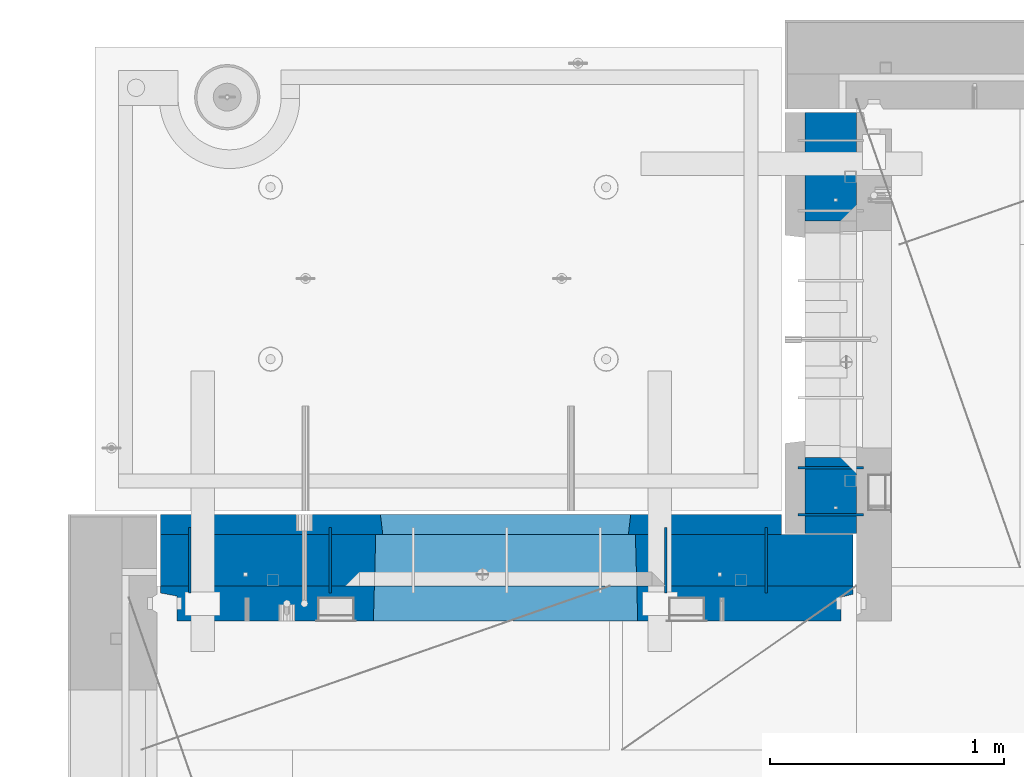
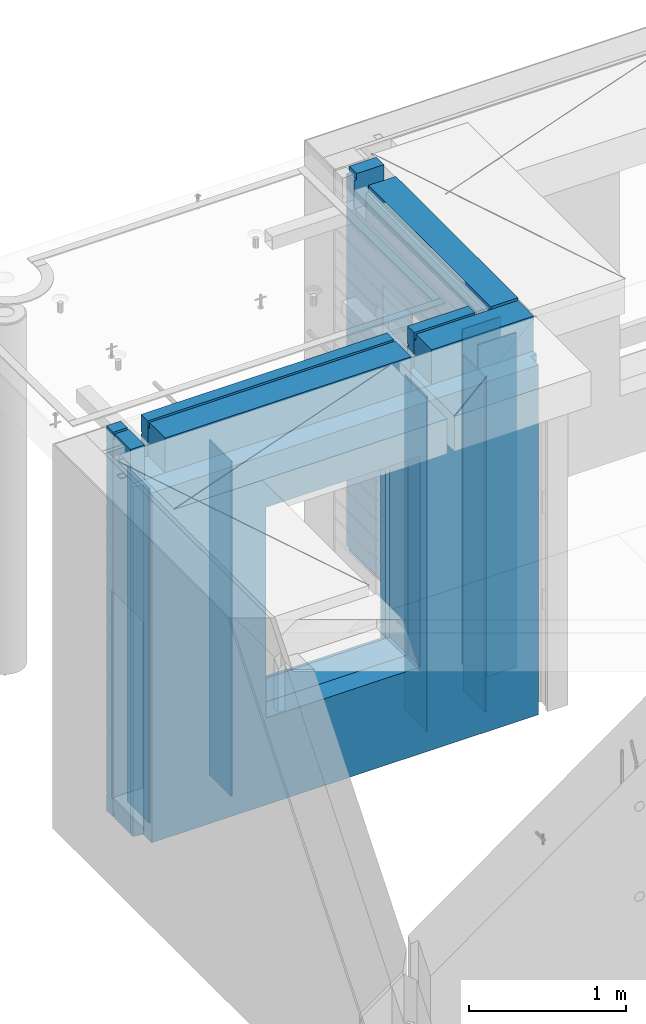
# One storey, part 236 of 352: 10 walls, 2 elements without a shape of their own.
"""IFC2X3 building model written with IfcOpenShell, lengths in millimetres."""

from ifc_helpers import new_model, si_unit, frame, origin_with_axes, place, context, subcontext, project, spatial, faceted_brep, material, type_object, element, aggregate, save


model = new_model("IFC2X3")

# Units and contexts
model_context = context("Model", 3, precision=1e-05, world=origin_with_axes())
body_context = subcontext(model_context, "Body", "Model", "MODEL_VIEW")
ifc_project = project(units=[si_unit("LENGTHUNIT", "METRE", prefix="MILLI"), si_unit("AREAUNIT", "SQUARE_METRE"), si_unit("VOLUMEUNIT", "CUBIC_METRE"), si_unit("MASSUNIT", "GRAM", prefix="KILO"), si_unit("TIMEUNIT", "SECOND"), si_unit("PLANEANGLEUNIT", "RADIAN"), si_unit("SOLIDANGLEUNIT", "STERADIAN"), si_unit("THERMODYNAMICTEMPERATUREUNIT", "DEGREE_CELSIUS"), si_unit("LUMINOUSINTENSITYUNIT", "LUMEN")], contexts=[model_context])

# Site, building, storey
site_placement = place(None, origin_with_axes())
site = spatial("IfcSite", under=ifc_project, at=site_placement, CompositionType="ELEMENT")
building_placement = place(site_placement, origin_with_axes())
building = spatial("IfcBuilding", under=site, at=building_placement, CompositionType="ELEMENT")
storey_placement = place(building_placement, origin_with_axes())
storey = spatial("IfcBuildingStorey", under=building, at=storey_placement, Name="6", CompositionType="ELEMENT", Elevation=0.0)

# Assembly, wall
assembly_1_placement = place(storey_placement, origin_with_axes())
assembly_1 = element("IfcElementAssembly", 1, at=assembly_1_placement, inside=storey, AssemblyPlace="NOTDEFINED", PredefinedType="REINFORCEMENT_UNIT")
ifc_material_1 = material(Name="Undefined")
wall_type_1 = type_object("IfcWallType", PredefinedType="NOTDEFINED")
wall_1_placement = place(assembly_1_placement, frame((10605.0002441406, 20549.9951872276, 98115.0), z_axis=(0.0, 0.0, 1.0), x_axis=(0.0, 1.0, 0.0)))
wall_1 = element("IfcWall", 2, at=wall_1_placement, type_object=wall_type_1, material=ifc_material_1, Name="(PD)", context=body_context, shape_type="Brep", body=[
    faceted_brep([(0.0, 5.0, -1300.0), (0.0, 5.0, 1300.0), (280.0, 5.0, 1300.0), (280.0, 5.0, -1300.0), (0.0, -5.0, 1300.0), (280.0, -5.0, 1300.0), (0.0, -5.0, -1300.0), (280.0, -5.0, -1300.0)], [[[0, 1, 2, 3]], [[1, 4, 5, 2]], [[4, 6, 7, 5]], [[6, 0, 3, 7]], [[5, 7, 3, 2]], [[6, 4, 1, 0]]]),
])

assembly_2_placement = place(storey_placement, origin_with_axes())
assembly_2 = element("IfcElementAssembly", 3, at=assembly_2_placement, inside=storey, AssemblyPlace="NOTDEFINED", PredefinedType="REINFORCEMENT_UNIT")
wall_2_placement = place(assembly_2_placement, frame((11020.0, 20885.0002441406, 98115.0), z_axis=(0.0, 0.0, 1.0), x_axis=(-1.0, 3.00000001838171e-08, 0.0)))
wall_2 = element("IfcWall", 4, at=wall_2_placement, type_object=wall_type_1, material=ifc_material_1, Name="(PD)", context=body_context, shape_type="Brep", body=[
    faceted_brep([(0.0, 5.0, -1300.0), (0.0, 5.0, 1300.0), (280.0, 5.0, 1300.0), (280.0, 5.0, -1300.0), (0.0, -5.0, 1300.0), (280.0, -5.0, 1300.0), (0.0, -5.0, -1300.0), (280.0, -5.0, -1300.0)], [[[0, 1, 2, 3]], [[1, 4, 5, 2]], [[4, 6, 7, 5]], [[6, 0, 3, 7]], [[5, 7, 3, 2]], [[6, 4, 1, 0]]]),
])

# Wall
wall_3_placement = place(assembly_1_placement, frame((8140.00024414063, 20549.9951872276, 98115.0), z_axis=(0.0, 0.0, 1.0), x_axis=(0.0, 1.0, 0.0)))
wall_3 = element("IfcWall", 5, at=wall_3_placement, type_object=wall_type_1, material=ifc_material_1, Name="(PD)", context=body_context, shape_type="Brep", body=[
    faceted_brep([(0.0, 5.0, -1300.0), (0.0, 5.0, 1300.0), (280.0, 5.0, 1300.0), (280.0, 5.0, -1300.0), (0.0, -5.0, 1300.0), (280.0, -5.0, 1300.0), (0.0, -5.0, -1300.0), (280.0, -5.0, -1300.0)], [[[0, 1, 2, 3]], [[1, 4, 5, 2]], [[4, 6, 7, 5]], [[6, 0, 3, 7]], [[5, 7, 3, 2]], [[6, 4, 1, 0]]]),
])

wall_4_placement = place(assembly_1_placement, frame((8740.00024414063, 20549.9951872276, 98115.0), z_axis=(0.0, 0.0, 1.0), x_axis=(0.0, 1.0, 0.0)))
wall_4 = element("IfcWall", 6, at=wall_4_placement, type_object=wall_type_1, material=ifc_material_1, Name="(PD)", context=body_context, shape_type="Brep", body=[
    faceted_brep([(0.0, 5.0, -1300.0), (0.0, 5.0, 1300.0), (280.0, 5.0, 1300.0), (280.0, 5.0, -1300.0), (0.0, -5.0, 1300.0), (280.0, -5.0, 1300.0), (0.0, -5.0, -1300.0), (280.0, -5.0, -1300.0)], [[[0, 1, 2, 3]], [[1, 4, 5, 2]], [[4, 6, 7, 5]], [[6, 0, 3, 7]], [[5, 7, 3, 2]], [[6, 4, 1, 0]]]),
])

wall_5_placement = place(assembly_1_placement, frame((10175.0002441406, 20549.9951872276, 98115.0), z_axis=(0.0, 0.0, 1.0), x_axis=(0.0, 1.0, 0.0)))
wall_5 = element("IfcWall", 7, at=wall_5_placement, type_object=wall_type_1, material=ifc_material_1, Name="(PD)", context=body_context, shape_type="Brep", body=[
    faceted_brep([(0.0, 5.0, -1300.0), (0.0, 5.0, 1300.0), (280.0, 5.0, 1300.0), (280.0, 5.0, -1300.0), (0.0, -5.0, 1300.0), (280.0, -5.0, 1300.0), (0.0, -5.0, -1300.0), (280.0, -5.0, -1300.0)], [[[0, 1, 2, 3]], [[1, 4, 5, 2]], [[4, 6, 7, 5]], [[6, 0, 3, 7]], [[5, 7, 3, 2]], [[6, 4, 1, 0]]]),
])

wall_6_placement = place(assembly_2_placement, frame((11020.0, 21085.0002441406, 98115.0), z_axis=(0.0, 0.0, 1.0), x_axis=(-1.0, 3.00000001838171e-08, 0.0)))
wall_6 = element("IfcWall", 8, at=wall_6_placement, type_object=wall_type_1, material=ifc_material_1, Name="(PD)", context=body_context, shape_type="Brep", body=[
    faceted_brep([(0.0, 5.0, -1300.0), (0.0, 5.0, 1300.0), (280.0, 5.0, 1300.0), (280.0, 5.0, -1300.0), (0.0, -5.0, 1300.0), (280.0, -5.0, 1300.0), (0.0, -5.0, -1300.0), (280.0, -5.0, -1300.0)], [[[0, 1, 2, 3]], [[1, 4, 5, 2]], [[4, 6, 7, 5]], [[6, 0, 3, 7]], [[5, 7, 3, 2]], [[6, 4, 1, 0]]]),
])

ifc_material_2 = material(Name="COS5gt")
wall_type_2 = type_object("IfcWallType", PredefinedType="NOTDEFINED")
wall_7_placement = place(assembly_1_placement, frame((8000.0, 20689.9951872276, 98247.5), z_axis=(0.0, 0.0, 1.0), x_axis=(1.0, 0.0, 0.0)))
wall_7 = element("IfcWall", 9, at=wall_7_placement, type_object=wall_type_2, material=ifc_material_2, context=body_context, shape_type="Brep", body=[
    faceted_brep([(15.0, 110.0, 1442.5), (15.0, 90.0, 1442.5), (119.999999999998, 90.0, 1442.5), (119.999999999998, 110.0, 1442.5), (15.0, 90.0, 1492.5), (119.999999999998, 90.0, 1492.5), (15.0, -110.0, 1492.5), (119.999999999998, -110.0, 1492.5), (119.999999999998, -110.0, 1222.5), (119.999999999998, 110.0, 1222.5), (269.999999999998, -110.0, 1222.5), (269.999999999998, 110.0, 1222.5), (269.999999999998, 110.0, 1442.5), (269.999999999998, 90.0, 1442.5), (2075.0, 90.0, 1442.5), (2075.0, 110.0, 1442.5), (269.999999999998, 90.0, 1492.5), (2075.0, 90.0, 1492.5), (269.999999999998, -110.0, 1492.5), (2075.0, -110.0, 1492.5), (2075.0, -110.000000000004, 1222.5), (2075.0, 109.999999999996, 1222.5), (2225.0, -110.000000000004, 1222.5), (2225.0, 109.999999999996, 1222.5), (2975.0, -110.0, 1492.5), (2975.0, 90.0, 1492.5), (2225.0, 90.0, 1492.5), (2225.0, -110.0, 1492.5), (2975.0, -110.0, -1492.5), (15.0, -110.0, -1492.5), (15.0, 90.0, -1492.5), (2975.0, 90.0, -1492.5), (2975.0, 110.0, 1442.5), (2975.0, 90.0, 1442.5), (2975.0, 90.0, -1442.5), (2975.0, 110.0, -1442.5), (2225.0, 110.0, 1442.5), (2225.0, 90.0, 1442.5), (929.055290664681, -110.000000000004, -813.445945945947), (929.055290664681, -110.000000000004, 813.445945945947), (2050.94718255657, -110.000000000004, 813.445945945947), (2050.94718255657, -110.000000000004, -813.445945945947), (935.001236610628, 110.0, -802.5), (935.001236610628, 110.0, 807.5), (935.001236610628, 110.0, -807.5), (2045.00123661063, 110.0, -807.5), (2015.00123661063, 110.0, -807.5), (965.001236610628, 110.0, -807.5), (2045.00123661063, 110.0, 807.5), (2045.00123661063, 110.0, -802.5), (15.0, 110.0, -1442.5), (15.0, 90.0, -1442.5)], [[[0, 1, 2, 3]], [[1, 4, 5, 2]], [[4, 6, 7, 5]], [[3, 2, 5, 7, 8, 9]], [[9, 8, 10, 11]], [[12, 13, 14, 15]], [[13, 16, 17, 14]], [[12, 11, 10, 18, 16, 13]], [[16, 18, 19, 17]], [[15, 14, 17, 19, 20, 21]], [[21, 20, 22, 23]], [[24, 25, 26, 27]], [[28, 29, 30, 31]], [[32, 33, 25, 24, 28, 31, 34, 35]], [[33, 32, 36, 37]], [[25, 33, 37, 26]], [[36, 23, 22, 27, 26, 37]], [[20, 19, 18, 10, 8, 7, 6, 29, 28, 24, 27, 22], [38, 39, 40, 41]], [[42, 43, 39, 38, 44]], [[41, 45, 46, 47, 44, 38]], [[40, 48, 49, 45, 41]], [[39, 43, 48, 40]], [[32, 35, 50, 0, 3, 9, 11, 12, 15, 21, 23, 36], [42, 44, 47, 46, 45, 49, 48, 43]], [[30, 29, 6, 4, 1, 0, 50, 51]], [[35, 34, 51, 50]], [[31, 30, 51, 34]]]),
])

wall_8_placement = place(assembly_2_placement, frame((10880.0, 20805.0, 98247.5), z_axis=(0.0, 0.0, 1.0), x_axis=(0.0, 1.0, 0.0)))
wall_8 = element("IfcWall", 10, at=wall_8_placement, type_object=wall_type_2, material=ifc_material_2, context=body_context, shape_type="Brep", body=[
    faceted_brep([(1800.0, -110.0, 1492.5), (1800.0, 90.0, 1492.5), (1705.0, 90.0, 1492.5), (1705.0, -110.0, 1492.5), (1800.0, 90.0, 1442.5), (1800.0, 110.0, 1442.5), (1705.0, 110.0, 1442.5), (1705.0, 90.0, 1442.5), (0.0, 110.0, 1442.5), (0.0, 90.0, 1442.5), (1555.0, 90.0, 1442.5), (1555.0, 110.0, 1442.5), (0.0, -110.0, -1492.5), (0.0, 90.0, -1492.5), (325.000271651108, 90.0, -1492.5), (325.000271651108, -110.0, -1492.5), (0.0, 90.0, -1442.5), (325.000271651108, 90.0, -1442.5), (0.0, -110.0, 1492.5), (0.0, 90.0, 1492.5), (0.0, 110.0, -1442.5), (325.000271651108, 110.0, -1442.5), (325.000271651108, 110.0, 857.5), (325.000271651108, -110.0, 857.5), (1335.00027165111, 110.0, 857.5), (1335.00027165111, -110.0, 857.5), (1555.0, 110.0, 1222.5), (1705.0, 110.0, 1222.5), (1800.0, 110.0, -1442.5), (1335.00027165111, 110.0, -1442.5), (1800.0, 90.0, -1442.5), (1800.0, 90.0, -1492.5), (1335.00027165111, 90.0, -1492.5), (1335.00027165111, 90.0, -1442.5), (1800.0, -110.0, -1492.5), (1335.00027165111, -110.0, -1492.5), (1705.0, -110.0, 1222.5), (1555.0, -110.0, 1222.5), (1555.0, -110.0, 1492.5), (1555.0, 90.0, 1492.5)], [[[0, 1, 2, 3]], [[4, 5, 6, 7]], [[8, 9, 10, 11]], [[12, 13, 14, 15]], [[13, 16, 17, 14]], [[13, 12, 18, 19, 9, 8, 20, 16]], [[16, 20, 21, 17]], [[15, 14, 17, 21, 22, 23]], [[23, 22, 24, 25]], [[21, 20, 8, 11, 26, 27, 6, 5, 28, 29, 24, 22]], [[30, 31, 32, 33]], [[28, 30, 33, 29]], [[5, 4, 1, 0, 34, 31, 30, 28]], [[31, 34, 35, 32]], [[25, 24, 29, 33, 32, 35]], [[34, 0, 3, 36, 37, 38, 18, 12, 15, 23, 25, 35]], [[19, 18, 38, 39]], [[9, 19, 39, 10]], [[38, 37, 26, 11, 10, 39]], [[36, 27, 26, 37]], [[3, 2, 7, 6, 27, 36]], [[1, 4, 7, 2]]]),
])

aggregate(assembly_2, [wall_2, wall_6, wall_8])

ifc_material_3 = material(Name="CONCRETE/C30/37")
wall_type_3 = type_object("IfcWallType", PredefinedType="NOTDEFINED")
wall_9_placement = place(assembly_1_placement, frame((8000.0, 20842.4951872276, 98247.5), z_axis=(0.0, 0.0, 1.0), x_axis=(1.0, 0.0, 0.0)))
wall_9 = element("IfcWall", 11, at=wall_9_placement, type_object=wall_type_3, material=ifc_material_3, context=body_context, shape_type="Brep", body=[
    faceted_brep([(2670.0, -42.5, 1492.5), (2670.0, 42.5, 1492.5), (2225.0, 42.5, 1492.5), (2225.0, -42.5, 1492.5), (2670.0, 42.4999992431622, 1356.99999988925), (2225.0, 42.4999993700148, 1356.99999988925), (2670.0, 32.4999991126933, 1355.00000040043), (2670.0, 32.4999992506928, 1344.9999999992), (2225.0, 32.4999992506928, 1344.9999999992), (2225.0, 32.4999991126933, 1355.00000040043), (2670.0, 42.4999996036859, 1342.99999994476), (2225.0, 42.4999996701117, 1342.99999994476), (2670.0, 42.4999993831079, 892.999999944761), (15.0, 42.5, 892.999999944761), (15.0, 32.4999992506928, 894.9999999992), (2670.0, 32.4999992506928, 894.9999999992), (15.0, 32.4999991126933, 905.000000400425), (2670.0, 32.4999991126933, 905.000000400425), (2670.0, 42.4999992431622, 906.999999889245), (15.0, 42.5, 906.999999889245), (15.0, 42.5, 1042.99999994476), (2670.0, 42.4999994189602, 1042.99999994476), (15.0, 32.4999992506928, 1044.9999999992), (2670.0, 32.4999992506928, 1044.9999999992), (15.0, 32.4999991126933, 1055.00000040043), (2670.0, 32.4999991126933, 1055.00000040043), (2670.0, 42.4999992431622, 1056.99999988925), (15.0, 42.5, 1056.99999988925), (15.0, 42.5, 1192.99999994476), (2670.0, 42.4999994795107, 1192.99999994476), (15.0000000000009, 32.4999992506928, 1194.9999999992), (2670.0, 32.4999992506928, 1194.9999999992), (15.0000000000009, 32.4999991126933, 1205.00000040043), (2670.0, 32.4999991126933, 1205.00000040043), (2670.0, 42.4999992431622, 1206.99999988925), (15.0, 42.5, 1206.99999988925), (15.0, 32.4999992506928, 1344.9999999992), (15.0, 32.4999991126933, 1355.00000040043), (119.999999999998, 32.4999991126933, 1355.00000040043), (119.999999999998, 32.4999992506928, 1344.9999999992), (15.0, 42.5, 1342.99999994476), (119.999999999998, 42.4999999843276, 1342.99999994476), (269.999999999998, 32.4999992506928, 1344.9999999992), (269.999999999998, 32.4999991126933, 1355.00000040043), (2075.0, 32.4999991126933, 1355.00000040043), (2075.0, 32.4999992506928, 1344.9999999992), (269.999999999998, 42.4999999619358, 1342.99999994476), (2075.0, 42.4999996925035, 1342.99999994476), (119.999999999998, 42.4999999076099, 1222.5), (269.999999999998, 42.4999998750354, 1222.5), (2075.0, 42.4999994593163, 1222.5), (2225.0, 42.4999994264763, 1222.5), (119.999999999998, -42.5, 1222.5), (269.999999999998, -42.5, 1222.5), (269.999999999998, 42.5, 1492.5), (269.999999999998, 42.4999999273095, 1356.99999988925), (269.999999999998, -42.5, 1492.5), (2075.0, -42.5, 1492.5), (2075.0, 42.5, 1492.5), (2075.0, 42.4999994127757, 1356.99999988925), (2075.0, -42.5000000000036, 1222.5), (2225.0, -42.5000000000036, 1222.5), (2670.0, -42.5, -1492.5), (2670.0, 42.5, -1492.5), (2670.0, 42.5, -1357.00000005524), (2670.0, 32.4999992506928, -1355.0000000008), (2670.0, 32.4999991126933, -1344.99999959957), (2670.0, 42.4999992431622, -1343.00000011075), (2670.0, 42.4999992794619, -1207.00000005524), (2670.0, 32.4999992506928, -1205.0000000008), (2670.0, 32.4999991126933, -1194.99999959957), (2670.0, 42.4999992431622, -1193.00000011075), (2670.0, 42.4999992814919, -1057.00000005524), (2670.0, 32.4999992506928, -1055.0000000008), (2670.0, 32.4999991126933, -1044.99999959957), (2670.0, 42.4999992431622, -1043.00000011075), (2670.0, 42.4999992837584, -907.000000055239), (2670.0, 32.4999992506928, -905.0000000008), (2670.0, 32.4999991126933, -894.999999599575), (2670.0, 42.4999992431622, -893.000000110755), (2670.0, 42.4999992863086, -757.000000055239), (2670.0, 32.4999992506928, -755.0000000008), (2670.0, 32.4999991126933, -744.999999599575), (2670.0, 42.4999992431622, -743.000000110755), (2670.0, 42.4999992892044, -607.000000055239), (2670.0, 32.4999992506928, -605.0000000008), (2670.0, 32.4999991126933, -594.999999599575), (2670.0, 42.4999992431622, -593.000000110755), (2670.0, 42.4999992925186, -457.000000055239), (2670.0, 32.4999992506928, -455.0000000008), (2670.0, 32.4999991126933, -444.999999599575), (2670.0, 42.4999992431622, -443.000000110755), (2670.0, 42.4999992963421, -307.000000055239), (2670.0, 32.4999992506928, -305.0000000008), (2670.0, 32.4999991126933, -294.999999599575), (2670.0, 42.4999992431622, -293.000000110755), (2670.0, 42.4999993008096, -157.000000055239), (2670.0, 32.4999992506928, -155.0000000008), (2670.0, 32.4999991126933, -144.999999599575), (2670.0, 42.4999992431622, -143.000000110755), (2670.0, 42.4999993060956, -7.00000005523907), (2670.0, 32.4999992506928, -5.00000000080036), (2670.0, 32.4999991126933, 5.00000040042505), (2670.0, 42.4999992431622, 6.99999988924537), (2670.0, 42.4999993124511, 142.999999944761), (2670.0, 32.4999992506928, 144.9999999992), (2670.0, 32.4999991126933, 155.000000400425), (2670.0, 42.4999992431622, 156.999999889245), (2670.0, 42.4999993202327, 292.999999944761), (2670.0, 32.4999992506928, 294.9999999992), (2670.0, 32.4999991126933, 305.000000400425), (2670.0, 42.4999992431622, 306.999999889245), (2670.0, 42.4999993299862, 442.999999944761), (2670.0, 32.4999992506928, 444.9999999992), (2670.0, 32.4999991126933, 455.000000400425), (2670.0, 42.4999992431622, 456.999999889245), (2670.0, 42.4999993425627, 592.999999944761), (2670.0, 32.4999992506928, 594.9999999992), (2670.0, 32.4999991126933, 605.000000400425), (2670.0, 42.4999992431622, 606.999999889245), (2670.0, 42.4999993594029, 742.999999944761), (2670.0, 32.4999992506928, 744.9999999992), (2670.0, 32.4999991126933, 755.000000400425), (2670.0, 42.4999992431622, 756.999999889245), (15.0, -42.5, -1492.5), (15.0, 42.5, -1492.5), (15.0, 42.5, -1357.00000005524), (15.0, 32.4999992506928, -1355.0000000008), (15.0, 32.4999991126933, -1344.99999959957), (15.0, 42.5, -1343.00000011075), (15.0, 42.5, -1207.00000005524), (15.0, 32.4999992506928, -1205.0000000008), (15.0, 32.4999991126933, -1194.99999959957), (15.0, 42.5, -1193.00000011075), (15.0, 42.5, -1057.00000005524), (15.0, 32.4999992506928, -1055.0000000008), (15.0, 32.4999991126933, -1044.99999959957), (15.0, 42.5, -1043.00000011075), (15.0, 42.5, -907.000000055239), (15.0000000000009, 32.4999992506928, -905.0000000008), (15.0000000000009, 32.4999991126933, -894.999999599575), (15.0, 42.5, -893.000000110755), (15.0, 32.4999991126933, 755.000000400425), (15.0, 42.5, 756.999999889245), (955.001236610628, 42.499999732041, 756.999999889245), (956.177707303252, 32.4999991126933, 755.000000400425), (15.0, 32.4999992506928, 744.9999999992), (956.177707287017, 32.4999992506928, 744.9999999992), (15.0, 42.5, 742.999999944761), (955.001236610628, 42.4999997731975, 742.999999944761), (15.0, 42.5, 606.999999889245), (955.001236610628, 42.499999732041, 606.999999889245), (15.0, 32.4999991126933, 605.000000400425), (956.177707303252, 32.4999991126933, 605.000000400425), (15.0, 32.4999992506928, 594.9999999992), (956.177707287017, 32.4999992506928, 594.9999999992), (15.0, 42.5, 592.999999944761), (955.001236610628, 42.4999997672348, 592.999999944761), (15.0, 42.5, 456.999999889245), (955.001236610628, 42.499999732041, 456.999999889245), (15.0, 32.4999991126933, 455.000000400425), (956.177707303252, 32.4999991126933, 455.000000400425), (15.0, 32.4999992506928, 444.9999999992), (956.177707287017, 32.4999992506928, 444.9999999992), (15.0, 42.5, 442.999999944761), (955.001236610628, 42.499999762782, 442.999999944761), (15.0, 42.5, 306.999999889245), (955.001236610628, 42.499999732041, 306.999999889245), (15.0, 32.4999991126933, 305.000000400425), (956.177707303252, 32.4999991126933, 305.000000400425), (15.0, 32.4999992506928, 294.9999999992), (956.177707287017, 32.4999992506928, 294.9999999992), (15.0, 42.5, 292.999999944761), (955.001236610628, 42.4999997593295, 292.999999944761), (15.0, 42.5, 156.999999889245), (955.001236610628, 42.499999732041, 156.999999889245), (15.0000000000009, 32.4999991126933, 155.000000400425), (956.177707303254, 32.4999991126933, 155.000000400425), (15.0000000000009, 32.4999992506928, 144.9999999992), (956.177707287017, 32.4999992506928, 144.9999999992), (15.0, 42.5, 142.999999944761), (955.001236610628, 42.4999997565719, 142.999999944761), (15.0, 42.5, 6.99999988924537), (955.001236610628, 42.499999732041, 6.99999988924537), (14.9999999999991, 32.4999991126933, 5.00000040042505), (956.177707303254, 32.4999991126933, 5.00000040042505), (14.9999999999991, 32.4999992506928, -5.00000000080036), (956.177707287017, 32.4999992506928, -5.00000000080036), (15.0, 42.5, -7.00000005523907), (955.001236610628, 42.4999997543237, -7.00000005523907), (15.0, 42.5, -143.000000110755), (955.001236610628, 42.499999732041, -143.000000110755), (15.0000000000009, 32.4999991126933, -144.999999599575), (956.177707303254, 32.4999991126933, -144.999999599575), (15.0000000000009, 32.4999992506928, -155.0000000008), (956.177707287017, 32.4999992506928, -155.0000000008), (15.0, 42.5, -157.000000055239), (955.001236610628, 42.4999997524537, -157.000000055239), (15.0, 42.5, -293.000000110755), (955.001236610628, 42.499999732041, -293.000000110755), (15.0, 32.4999991126933, -294.999999599575), (956.177707303252, 32.4999991126933, -294.999999599575), (15.0, 32.4999992506928, -305.0000000008), (956.177707287017, 32.4999992506928, -305.0000000008), (15.0, 42.5, -307.000000055239), (955.001236610628, 42.4999997508712, -307.000000055239), (15.0, 42.5, -443.000000110755), (955.001236610628, 42.499999732041, -443.000000110755), (15.0000000000009, 32.4999991126933, -444.999999599575), (956.177707303254, 32.4999991126933, -444.999999599575), (15.0000000000009, 32.4999992506928, -455.0000000008), (956.177707287017, 32.4999992506928, -455.0000000008), (15.0, 42.5, -457.000000055239), (955.001236610628, 42.4999997495179, -457.000000055239), (15.0, 42.5, -593.000000110755), (955.001236610628, 42.499999732041, -593.000000110755), (15.0, 32.4999991126933, -594.999999599575), (956.177707303252, 32.4999991126933, -594.999999599575), (15.0, 32.4999992506928, -605.0000000008), (956.177707287017, 32.4999992506928, -605.0000000008), (15.0, 42.5, -607.000000055239), (955.001236610628, 42.4999997483428, -607.000000055239), (15.0, 42.5, -743.000000110755), (955.001236610628, 42.499999732041, -743.000000110755), (15.0, 32.4999991126933, -744.999999599575), (956.177707303252, 32.4999991126933, -744.999999599575), (15.0, 32.4999992506928, -755.0000000008), (956.177707287017, 32.4999992506928, -755.0000000008), (15.0, 42.5, -757.000000055239), (955.001236610628, 42.4999997473169, -757.000000055239), (955.001236610628, 42.5, -857.5), (965.001236610628, -42.5, -807.5), (2015.00123661063, -42.5, -807.5), (2025.00123661063, 42.5, -857.5), (2025.00123661063, 42.499999459691, -757.000000055239), (2023.82476593424, 32.4999992506928, -755.0000000008), (2023.824765918, 32.4999991126933, -744.999999599575), (2025.00123661063, 42.4999994270256, -743.000000110755), (2025.00123661063, 42.4999994618847, -607.000000055239), (2023.82476593424, 32.4999992506928, -605.0000000008), (2023.824765918, 32.4999991126933, -594.999999599575), (2025.00123661063, 42.4999994270256, -593.000000110755), (2025.00123661063, 42.4999994643913, -457.000000055239), (2023.82476593424, 32.4999992506928, -455.0000000008), (2023.824765918, 32.4999991126933, -444.999999599575), (2025.00123661063, 42.4999994270256, -443.000000110755), (2025.00123661063, 42.4999994672871, -307.000000055239), (2023.82476593424, 32.4999992506928, -305.0000000008), (2023.824765918, 32.4999991126933, -294.999999599575), (2025.00123661063, 42.4999994270256, -293.000000110755), (2025.00123661063, 42.4999994706704, -157.000000055239), (2023.82476593424, 32.4999992506928, -155.0000000008), (2023.824765918, 32.4999991126933, -144.999999599575), (2025.00123661063, 42.4999994270256, -143.000000110755), (2025.00123661063, 42.4999994746722, -7.00000005523907), (2023.82476593424, 32.4999992506928, -5.00000000080036), (2023.824765918, 32.4999991126933, 5.00000040042505), (2025.00123661063, 42.4999994270256, 6.99999988924537), (2025.00123661063, 42.4999994794816, 142.999999944761), (2023.82476593424, 32.4999992506928, 144.9999999992), (2023.824765918, 32.4999991126933, 155.000000400425), (2025.00123661063, 42.4999994270256, 156.999999889245), (2025.00123661063, 42.4999994853752, 292.999999944761), (2023.82476593424, 32.4999992506928, 294.9999999992), (2023.824765918, 32.4999991126933, 305.000000400425), (2025.00123661063, 42.4999994270256, 306.999999889245), (2025.00123661063, 42.4999994927566, 442.999999944761), (2023.82476593424, 32.4999992506928, 444.9999999992), (2023.824765918, 32.4999991126933, 455.000000400425), (2025.00123661063, 42.4999994270256, 456.999999889245), (2025.00123661063, 42.4999995022772, 592.999999944761), (2023.82476593424, 32.4999992506928, 594.9999999992), (2023.824765918, 32.4999991126933, 605.000000400425), (2025.00123661063, 42.4999994270256, 606.999999889245), (2025.00123661063, 42.4999995150283, 742.999999944761), (2023.82476593424, 32.4999992506928, 744.9999999992), (2023.824765918, 32.4999991126933, 755.000000400425), (2025.00123661063, 42.4999994270256, 756.999999889245), (965.001236610628, 42.5, 782.5), (955.001236610628, 42.5, 782.5), (2025.00123661063, 42.5, 782.5), (2015.00123661063, 42.5, 782.5), (965.001236610628, -42.5, 782.5), (965.001236610628, -42.5, 787.5), (2015.00123661063, -42.5, 787.5), (2015.00123661063, -42.5, 782.5), (119.999999999998, -42.5, 1492.5), (15.0, -42.5, 1492.5), (15.0, 42.5, 1492.5), (119.999999999998, 42.5, 1492.5), (15.0, 42.5, 1356.99999988925), (119.999999999998, 42.4999999700703, 1356.99999988925)], [[[0, 1, 2, 3]], [[1, 4, 5, 2]], [[6, 7, 8, 9]], [[7, 10, 11, 8]], [[12, 13, 14, 15]], [[15, 14, 16, 17]], [[18, 17, 16, 19]], [[18, 19, 20, 21]], [[21, 20, 22, 23]], [[23, 22, 24, 25]], [[26, 25, 24, 27]], [[26, 27, 28, 29]], [[29, 28, 30, 31]], [[31, 30, 32, 33]], [[34, 33, 32, 35]], [[36, 37, 38, 39]], [[40, 36, 39, 41]], [[42, 43, 44, 45]], [[46, 42, 45, 47]], [[10, 34, 35, 40, 41, 48, 49, 46, 47, 50, 51, 11]], [[48, 52, 53, 49]], [[54, 55, 43, 42, 46, 49, 53, 56]], [[54, 56, 57, 58]], [[55, 54, 58, 59]], [[43, 55, 59, 44]], [[58, 57, 60, 50, 47, 45, 44, 59]], [[50, 60, 61, 51]], [[2, 5, 9, 8, 11, 51, 61, 3]], [[4, 6, 9, 5]], [[1, 0, 62, 63, 64, 65, 66, 67, 68, 69, 70, 71, 72, 73, 74, 75, 76, 77, 78, 79, 80, 81, 82, 83, 84, 85, 86, 87, 88, 89, 90, 91, 92, 93, 94, 95, 96, 97, 98, 99, 100, 101, 102, 103, 104, 105, 106, 107, 108, 109, 110, 111, 112, 113, 114, 115, 116, 117, 118, 119, 120, 121, 122, 123, 12, 15, 17, 18, 21, 23, 25, 26, 29, 31, 33, 34, 10, 7, 6, 4]], [[124, 125, 63, 62]], [[63, 125, 126, 64]], [[64, 126, 127, 65]], [[65, 127, 128, 66]], [[67, 66, 128, 129]], [[67, 129, 130, 68]], [[68, 130, 131, 69]], [[69, 131, 132, 70]], [[71, 70, 132, 133]], [[71, 133, 134, 72]], [[72, 134, 135, 73]], [[73, 135, 136, 74]], [[75, 74, 136, 137]], [[75, 137, 138, 76]], [[76, 138, 139, 77]], [[77, 139, 140, 78]], [[79, 78, 140, 141]], [[142, 143, 144, 145]], [[146, 142, 145, 147]], [[148, 146, 147, 149]], [[150, 148, 149, 151]], [[152, 150, 151, 153]], [[154, 152, 153, 155]], [[156, 154, 155, 157]], [[158, 156, 157, 159]], [[160, 158, 159, 161]], [[162, 160, 161, 163]], [[164, 162, 163, 165]], [[166, 164, 165, 167]], [[168, 166, 167, 169]], [[170, 168, 169, 171]], [[172, 170, 171, 173]], [[174, 172, 173, 175]], [[176, 174, 175, 177]], [[178, 176, 177, 179]], [[180, 178, 179, 181]], [[182, 180, 181, 183]], [[184, 182, 183, 185]], [[186, 184, 185, 187]], [[188, 186, 187, 189]], [[190, 188, 189, 191]], [[192, 190, 191, 193]], [[194, 192, 193, 195]], [[196, 194, 195, 197]], [[198, 196, 197, 199]], [[200, 198, 199, 201]], [[202, 200, 201, 203]], [[204, 202, 203, 205]], [[206, 204, 205, 207]], [[208, 206, 207, 209]], [[210, 208, 209, 211]], [[212, 210, 211, 213]], [[214, 212, 213, 215]], [[216, 214, 215, 217]], [[218, 216, 217, 219]], [[220, 218, 219, 221]], [[222, 220, 221, 223]], [[224, 222, 223, 225]], [[226, 224, 225, 227]], [[228, 226, 227, 229]], [[230, 231, 232, 233]], [[80, 79, 141, 228, 229, 230, 233, 234]], [[81, 80, 234, 235]], [[82, 81, 235, 236]], [[83, 82, 236, 237]], [[84, 83, 237, 238]], [[85, 84, 238, 239]], [[86, 85, 239, 240]], [[87, 86, 240, 241]], [[88, 87, 241, 242]], [[89, 88, 242, 243]], [[90, 89, 243, 244]], [[91, 90, 244, 245]], [[92, 91, 245, 246]], [[93, 92, 246, 247]], [[94, 93, 247, 248]], [[95, 94, 248, 249]], [[96, 95, 249, 250]], [[97, 96, 250, 251]], [[98, 97, 251, 252]], [[99, 98, 252, 253]], [[100, 99, 253, 254]], [[101, 100, 254, 255]], [[102, 101, 255, 256]], [[103, 102, 256, 257]], [[104, 103, 257, 258]], [[105, 104, 258, 259]], [[106, 105, 259, 260]], [[107, 106, 260, 261]], [[108, 107, 261, 262]], [[109, 108, 262, 263]], [[110, 109, 263, 264]], [[111, 110, 264, 265]], [[112, 111, 265, 266]], [[113, 112, 266, 267]], [[114, 113, 267, 268]], [[115, 114, 268, 269]], [[116, 115, 269, 270]], [[117, 116, 270, 271]], [[118, 117, 271, 272]], [[119, 118, 272, 273]], [[120, 119, 273, 274]], [[121, 120, 274, 275]], [[122, 121, 275, 276]], [[123, 122, 276, 277]], [[278, 279, 144, 143, 13, 12, 123, 277, 280, 281]], [[282, 231, 230, 229, 227, 225, 223, 221, 219, 217, 215, 213, 211, 209, 207, 205, 203, 201, 199, 197, 195, 193, 191, 189, 187, 185, 183, 181, 179, 177, 175, 173, 171, 169, 167, 165, 163, 161, 159, 157, 155, 153, 151, 149, 147, 145, 144, 279, 283]], [[278, 281, 280, 284, 283, 279]], [[277, 276, 275, 274, 273, 272, 271, 270, 269, 268, 267, 266, 265, 264, 263, 262, 261, 260, 259, 258, 257, 256, 255, 254, 253, 252, 251, 250, 249, 248, 247, 246, 245, 244, 243, 242, 241, 240, 239, 238, 237, 236, 235, 234, 233, 232, 285, 284, 280]], [[60, 57, 56, 53, 52, 286, 287, 124, 62, 0, 3, 61], [232, 231, 282, 283, 284, 285]], [[288, 287, 286, 289]], [[36, 40, 35, 32, 30, 28, 27, 24, 22, 20, 19, 16, 14, 13, 143, 142, 146, 148, 150, 152, 154, 156, 158, 160, 162, 164, 166, 168, 170, 172, 174, 176, 178, 180, 182, 184, 186, 188, 190, 192, 194, 196, 198, 200, 202, 204, 206, 208, 210, 212, 214, 216, 218, 220, 222, 224, 226, 228, 141, 140, 139, 138, 137, 136, 135, 134, 133, 132, 131, 130, 129, 128, 127, 126, 125, 124, 287, 288, 290, 37]], [[37, 290, 291, 38]], [[289, 286, 52, 48, 41, 39, 38, 291]], [[290, 288, 289, 291]]]),
])

ifc_material_4 = material(Name="CONCRETE/C25/30")
wall_type_4 = type_object("IfcWallType", PredefinedType="NOTDEFINED")
wall_10_placement = place(assembly_1_placement, frame((8000.0, 20504.9951872276, 98112.5), z_axis=(0.0, 0.0, 1.0), x_axis=(1.0, 0.0, 0.0)))
wall_10 = element("IfcWall", 12, at=wall_10_placement, type_object=wall_type_4, material=ifc_material_4, context=body_context, shape_type="Brep", body=[
    faceted_brep([(2925.0, -75.0, 1357.5), (2925.0, -75.0, -1357.5), (2925.0, 27.0, -1357.5), (2925.0, 27.0, 1357.5), (2975.0, 75.0, 1357.5), (15.0, 75.0, 1357.5), (15.0, 45.0, 1357.5), (85.0, 32.0, 1357.5), (85.0, -75.0, 1357.5), (2975.0, 40.0, 1357.5), (85.0, 32.0, -1357.5), (85.0, -75.0, -1357.5), (15.0, 45.0, -1357.5), (15.0, 75.0, -1357.5), (2975.0, 75.0, -1357.5), (2975.0, 40.0, -1357.5), (925.001236610628, -75.0, 952.5), (929.055290664681, 75.0, 948.445945945947), (2050.94718255657, 75.0, 948.445945945947), (2055.00123661063, -75.0, 952.5), (929.055290664681, 75.0, -678.445945945947), (2050.94718255657, 75.0, -678.445945945947), (2055.00123661063, -75.0, -682.5), (925.001236610628, -75.0, -682.5)], [[[0, 1, 2, 3]], [[4, 5, 6, 7, 8, 0, 3, 9]], [[7, 10, 11, 8]], [[6, 12, 10, 7]], [[5, 13, 12, 6]], [[1, 11, 10, 12, 13, 14, 15, 2]], [[9, 3, 2, 15]], [[14, 4, 9, 15]], [[16, 17, 18, 19]], [[13, 5, 4, 14], [20, 21, 18, 17]], [[19, 18, 21, 22]], [[8, 11, 1, 0], [23, 16, 19, 22]], [[17, 16, 23, 20]], [[22, 21, 20, 23]]]),
])

aggregate(assembly_1, [wall_1, wall_3, wall_4, wall_5, wall_9, wall_7, wall_10])

save(model, "model.ifc")
